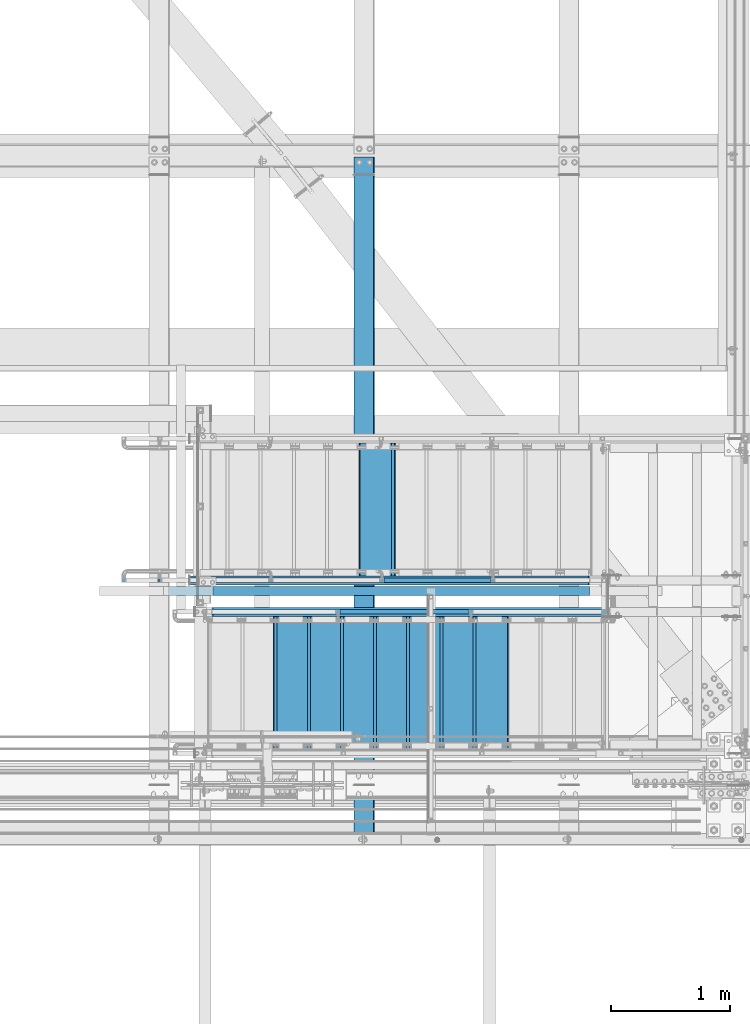
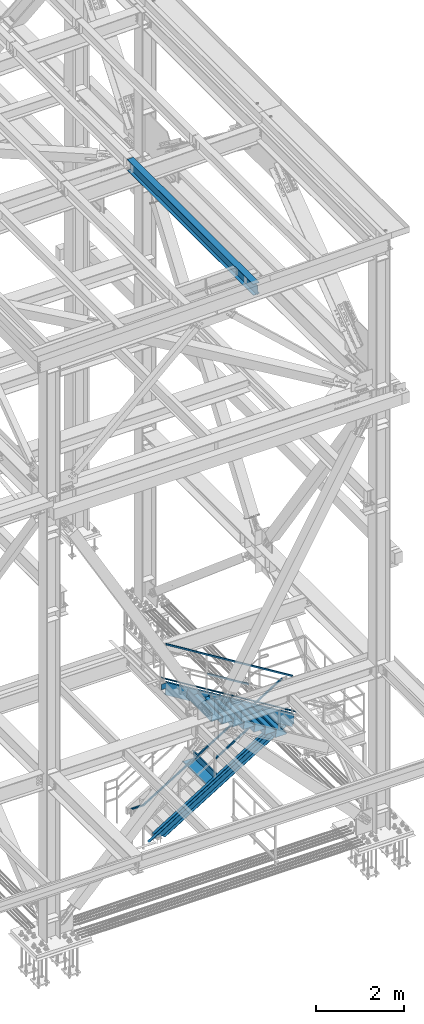
# One storey, part 1947 of 3843: 10 beams, 7 members, 7 elements without a shape of their own.
"""IFC2X3 building model written with IfcOpenShell, lengths in millimetres."""

from ifc_helpers import new_model, si_unit, frame, origin_with_axes, place, context, subcontext, project, spatial, faceted_brep, material, type_object, element, aggregate, save


model = new_model("IFC2X3")

# Units and contexts
model_context = context("Model", 3, precision=1e-05, world=origin_with_axes())
body_context = subcontext(model_context, "Body", "Model", "MODEL_VIEW")
ifc_project = project(units=[si_unit("LENGTHUNIT", "METRE", prefix="MILLI"), si_unit("AREAUNIT", "SQUARE_METRE"), si_unit("VOLUMEUNIT", "CUBIC_METRE"), si_unit("MASSUNIT", "GRAM", prefix="KILO"), si_unit("TIMEUNIT", "SECOND"), si_unit("PLANEANGLEUNIT", "RADIAN"), si_unit("SOLIDANGLEUNIT", "STERADIAN"), si_unit("THERMODYNAMICTEMPERATUREUNIT", "DEGREE_CELSIUS"), si_unit("LUMINOUSINTENSITYUNIT", "LUMEN")], contexts=[model_context])

# Site, building, storey
site_placement = place(None, origin_with_axes())
site = spatial("IfcSite", under=ifc_project, at=site_placement, CompositionType="ELEMENT")
building_placement = place(site_placement, origin_with_axes())
building = spatial("IfcBuilding", under=site, at=building_placement, Name="Undefined", CompositionType="ELEMENT")
storey_placement = place(building_placement, origin_with_axes())
storey = spatial("IfcBuildingStorey", under=building, at=storey_placement, Name="Undefined", CompositionType="ELEMENT", Elevation=0.0)

# Assembly, beam
assembly_1_placement = place(storey_placement, origin_with_axes())
assembly_1 = element("IfcElementAssembly", 1, at=assembly_1_placement, inside=storey, Name="RAIL", AssemblyPlace="NOTDEFINED", PredefinedType="RIGID_FRAME")
ifc_material_1 = material()
beam_type_1 = type_object("IfcBeamType", Name="HSS1-1/2X1-1/2X1/4", PredefinedType="NOTDEFINED")
beam_1_placement = place(assembly_1_placement, frame((84099.3999999465, 16725.9, 33781.9999999847), z_axis=(0.524097425775922, 0.0, -0.851658316635875), x_axis=(-0.851658316635875, 0.0, -0.524097425775922)))
beam_1 = element("IfcBeam", 2, at=beam_1_placement, type_object=beam_type_1, material=ifc_material_1, Name="RAIL", ObjectType="HSS1-1/2X1-1/2X1/4", context=body_context, shape_type="Brep", body=[
    faceted_brep([(-5.39195355401171, -19.0499992350015, -19.0499992349942), (5.39195347770146, -19.0499992350015, 19.0499992349796), (5.39195347770146, 19.0499992350015, 19.0499992349796), (-5.39195355401171, 19.0499992350015, -19.0499992349942), (3.59463559381402, 12.6999993300014, 12.6999993299833), (3.59463559381402, -12.6999993300014, 12.6999993299833), (-3.59463567009516, -12.6999993300014, -12.6999993299978), (-3.59463567009516, 12.6999993300014, -12.6999993299978), (4270.24785764143, -19.0499992349996, 19.0499992372643), (4270.24785764143, 19.0499992349996, 19.0499992372643), (4259.4639506097, 19.0499992349996, -19.049999232695), (4259.4639506097, -19.0499992349996, -19.049999232695), (4261.26126849362, -12.6999993299996, -12.6999993277132), (4261.26126849362, 12.6999993299996, -12.6999993277132), (4268.45053975753, 12.6999993299996, 12.6999993322825), (4268.45053975753, -12.6999993299996, 12.6999993322825), (4530.68139334727, 19.0499992350015, -185.9530417606), (4530.68139334727, -19.0499992350015, -185.9530417606), (4518.20132390667, -19.0499992350015, -133.536750079667), (4518.20132390667, 19.0499992350015, -133.536750079667), (4528.60138172143, -12.6999993300014, -177.216992926999), (4528.60138172143, 12.6999993300014, -177.216992926999), (4520.28133553253, 12.6999993300014, -142.27279891328), (4520.28133553253, -12.6999993300014, -142.27279891328)], [[[0, 1, 2, 3], [4, 5, 6, 7]], [[2, 1, 8, 9]], [[0, 3, 10, 11]], [[7, 6, 12, 13]], [[5, 4, 14, 15]], [[11, 10, 16, 17]], [[8, 1, 0, 11, 17, 18]], [[9, 8, 18, 19]], [[10, 3, 2, 9, 19, 16]], [[13, 12, 20, 21]], [[14, 4, 7, 13, 21, 22]], [[15, 14, 22, 23]], [[12, 6, 5, 15, 23, 20]], [[19, 18, 17, 16], [22, 21, 20, 23]]]),
])

# Assembly, member
assembly_2_placement = place(storey_placement, origin_with_axes())
assembly_2 = element("IfcElementAssembly", 3, at=assembly_2_placement, inside=storey, Name="RAIL", AssemblyPlace="NOTDEFINED", PredefinedType="RIGID_FRAME")
member_type_1 = type_object("IfcMemberType", Name="HSS1-1/2X1-1/2X1/4", PredefinedType="NOTDEFINED")
member_1_placement = place(assembly_2_placement, frame((83091.8666666392, 16459.2, 34134.343589332), z_axis=(0.524097425775922, 0.0, 0.851658316635875), x_axis=(-0.851658316635873, 0.0, 0.524097425775925)))
member_1 = element("IfcMember", 4, at=member_1_placement, type_object=member_type_1, material=ifc_material_1, Name="RAIL", ObjectType="HSS1-1/2X1-1/2X1/4", context=body_context, shape_type="Brep", body=[
    faceted_brep([(10.6450480494532, -19.0499992350015, -19.0499992349796), (34.091200960931, -19.0499992350015, 19.0499992349942), (34.091200960931, 19.0499992350015, 19.0499992349942), (10.6450480494532, 19.0499992350015, -19.0499992349796), (30.1835087105574, 12.6999993300014, 12.6999993299978), (30.1835087105574, -12.6999993300014, 12.6999993299978), (14.5527402998268, -12.6999993300014, -12.6999993299833), (14.5527402998268, 12.6999993300014, -12.6999993299833), (1283.14284868913, 19.0499992350015, -19.0499992342957), (1283.14284868913, -19.0499992350015, -19.0499992342957), (1306.58900160061, -19.0499992350015, 19.0499992356781), (1306.58900160061, 19.0499992350015, 19.0499992356781), (1302.68130935024, -12.6999993300014, 12.6999993306817), (1302.68130935024, 12.6999993300014, 12.6999993306817), (1287.0505409395, 12.6999993300014, -12.6999993292993), (1287.0505409395, -12.6999993300014, -12.6999993292993)], [[[0, 1, 2, 3], [4, 5, 6, 7]], [[8, 9, 0, 3]], [[9, 10, 1, 0]], [[10, 11, 2, 1]], [[11, 8, 3, 2]], [[10, 9, 8, 11], [12, 13, 14, 15]], [[13, 12, 5, 4]], [[14, 13, 4, 7]], [[15, 14, 7, 6]], [[12, 15, 6, 5]]]),
])

# Member
member_2_placement = place(assembly_1_placement, frame((82340.4500000268, 16725.9, 32166.1692304858), z_axis=(-0.524097425775922, 0.0, 0.851658316635875), x_axis=(0.851658316635872, 0.0, 0.524097425775926)))
member_2 = element("IfcMember", 5, at=member_2_placement, type_object=member_type_1, material=ifc_material_1, Name="RAIL", ObjectType="HSS1-1/2X1-1/2X1/4", context=body_context, shape_type="Brep", body=[
    faceted_brep([(1089.12111513855, -19.0499999999993, 19.0499992355581), (1065.67496222707, -19.0499992350015, -19.0499992344157), (1065.67496222707, 19.0499992350015, -19.0499992344157), (1089.12111513855, 19.0499992350015, 19.0499992355581), (1085.21342288818, -12.6999993300014, 12.6999993305617), (1085.21342288818, 12.6999993300014, 12.6999993305617), (1069.58265447745, 12.6999993300014, -12.6999993294194), (1069.58265447745, -12.6999993300014, -12.6999993294194), (10.6450480494532, 19.0499992350015, -19.0499992349796), (34.091200960931, 19.0499992350015, 19.0499992349942), (34.091200960931, -19.0499992350015, 19.0499992349942), (10.6450480494532, -19.0499992350015, -19.0499992349796), (30.1835087105574, 12.6999993300014, 12.6999993299978), (30.1835087105574, -12.6999993300014, 12.6999993299978), (14.5527402998268, -12.6999993300014, -12.6999993299833), (14.5527402998268, 12.6999993300014, -12.6999993299833)], [[[0, 1, 2, 3], [4, 5, 6, 7]], [[8, 9, 3, 2]], [[9, 10, 0, 3]], [[10, 11, 1, 0]], [[11, 8, 2, 1]], [[11, 10, 9, 8], [12, 13, 14, 15]], [[14, 13, 4, 7]], [[15, 14, 7, 6]], [[12, 15, 6, 5]], [[13, 12, 5, 4]]]),
])

aggregate(assembly_1, [member_2, beam_1])

member_3_placement = place(assembly_2_placement, frame((80898.9999999723, 16459.2, 36017.2000000046), z_axis=(-0.524097425775922, 0.0, -0.851658316635875), x_axis=(0.851658316635874, 0.0, -0.524097425775923)))
member_3 = element("IfcMember", 6, at=member_3_placement, type_object=member_type_1, material=ifc_material_1, Name="RAIL", ObjectType="HSS1-1/2X1-1/2X1/4", context=body_context, shape_type="Brep", body=[
    faceted_brep([(-3.59463567009516, 12.6999993300014, -12.6999993299978), (-3.59463567009516, -12.6999993300014, -12.6999993299978), (3899.15051320208, -12.6999993300014, -12.6999993279023), (3899.15051320208, 12.6999993300014, -12.6999993279023), (3.59463559381402, -12.6999993300014, 12.6999993299833), (3884.957116021, -12.6999993300014, 12.6999993320496), (3.59463559381402, 12.6999993300014, 12.6999993299833), (3884.957116021, 12.6999993300014, 12.6999993320496), (-5.39195355401171, 19.0499992350015, -19.0499992349942), (5.39195347770146, 19.0499992350015, 19.0499992349796), (3881.40876659161, 19.0499992350015, 19.0499992370605), (3902.69886263146, 19.0499992350015, -19.0499992328987), (5.39195347770146, -19.0499992350015, 19.0499992349796), (3881.40876659161, -19.0499992350015, 19.0499992370605), (-5.39195355401171, -19.0499992350015, -19.0499992349942), (3902.69886263146, -19.0499992350015, -19.0499992328987)], [[[0, 1, 2, 3]], [[1, 4, 5, 2]], [[4, 6, 7, 5]], [[6, 0, 3, 7]], [[8, 9, 10, 11]], [[9, 12, 13, 10]], [[12, 14, 15, 13]], [[14, 8, 11, 15]], [[13, 15, 11, 10], [5, 7, 3, 2]], [[14, 12, 9, 8], [6, 4, 1, 0]]]),
])

aggregate(assembly_2, [member_1, member_3])

# Assembly, beams
assembly_3_placement = place(storey_placement, origin_with_axes())
assembly_3 = element("IfcElementAssembly", 7, at=assembly_3_placement, inside=storey, Name="STAIR", AssemblyPlace="NOTDEFINED", PredefinedType="RIGID_FRAME")
ifc_material_2 = material(Name="STEEL/ASTM A1011")
beam_type_2 = type_object("IfcBeamType", PredefinedType="NOTDEFINED")
beam_2_placement = place(assembly_3_placement, frame((81432.3999999869, 15862.300000067, 34604.9355769223), z_axis=(0.0, 1.0, 0.0), x_axis=(1.0, 0.0, 0.0)))
beam_2 = element("IfcBeam", 8, at=beam_2_placement, type_object=beam_type_2, material=ifc_material_2, Name="TREAD", context=body_context, shape_type="Brep", body=[
    faceted_brep([(0.0, -1.58750000000146, -558.799999999999), (0.0, -1.58750000000146, 558.799999999999), (0.0, 1.58750000000146, 558.799999999999), (0.0, 1.58750000000146, -558.799999999999), (21.7215083258779, 1.58750000000146, 558.799999999999), (21.7215083258779, 1.58750000000146, -558.799999999999), (25.3999999999942, -1.58750000000146, -558.799999999999), (25.3999999999942, -1.58750000000146, 558.799999999999), (-11.1830371286633, 224.325961538467, 558.799999999999), (-11.1830371286633, 224.325961538467, -558.799999999999), (-7.50454545454704, 221.150961538464, -558.799999999999), (-7.50454545454704, 221.150961538464, 558.799999999999), (293.616962871325, 224.325961538467, 558.799999999999), (293.616962871325, 224.325961538467, -558.799999999999), (290.876539379024, 221.150961538464, -558.799999999999), (290.876539379024, 221.150961538464, 558.799999999999), (299.585432747743, 183.924011605752, 558.799999999999), (299.585432747743, 183.924011605752, -558.799999999999), (296.444520385252, 183.460013188564, 558.799999999999), (296.444520385252, 183.460013188564, -558.799999999999)], [[[0, 1, 2, 3]], [[3, 2, 4, 5]], [[1, 0, 6, 7]], [[5, 4, 8, 9]], [[7, 6, 10, 11]], [[9, 8, 12, 13]], [[11, 10, 14, 15]], [[13, 12, 16, 17]], [[12, 8, 4, 2, 1, 7, 11, 15, 18, 16]], [[15, 14, 19, 18]], [[14, 10, 6, 0, 3, 5, 9, 13, 17, 19]], [[18, 19, 17, 16]]]),
])
beam_3_placement = place(assembly_3_placement, frame((81711.7999999869, 15862.300000067, 34432.9971153838), z_axis=(0.0, 1.0, 0.0), x_axis=(1.0, 0.0, 0.0)))
beam_3 = element("IfcBeam", 9, at=beam_3_placement, type_object=beam_type_2, material=ifc_material_2, Name="TREAD", context=body_context, shape_type="Brep", body=[
    faceted_brep([(0.0, -1.58750000000146, -558.799999999999), (0.0, -1.58750000000146, 558.799999999999), (0.0, 1.58750000000146, 558.799999999999), (0.0, 1.58750000000146, -558.799999999999), (21.7215083258779, 1.58750000000146, 558.799999999999), (21.7215083258779, 1.58750000000146, -558.799999999999), (25.3999999999942, -1.58750000000146, -558.799999999999), (25.3999999999942, -1.58750000000146, 558.799999999999), (-11.1830371286633, 224.325961538467, 558.799999999999), (-11.1830371286633, 224.325961538467, -558.799999999999), (-7.50454545454704, 221.150961538464, -558.799999999999), (-7.50454545454704, 221.150961538464, 558.799999999999), (293.616962871325, 224.325961538467, 558.799999999999), (293.616962871325, 224.325961538467, -558.799999999999), (290.876539379024, 221.150961538464, -558.799999999999), (290.876539379024, 221.150961538464, 558.799999999999), (299.585432747743, 183.924011605752, 558.799999999999), (299.585432747743, 183.924011605752, -558.799999999999), (296.444520385252, 183.460013188564, 558.799999999999), (296.444520385252, 183.460013188564, -558.799999999999)], [[[0, 1, 2, 3]], [[3, 2, 4, 5]], [[1, 0, 6, 7]], [[5, 4, 8, 9]], [[7, 6, 10, 11]], [[9, 8, 12, 13]], [[11, 10, 14, 15]], [[13, 12, 16, 17]], [[12, 8, 4, 2, 1, 7, 11, 15, 18, 16]], [[15, 14, 19, 18]], [[14, 10, 6, 0, 3, 5, 9, 13, 17, 19]], [[18, 19, 17, 16]]]),
])
beam_4_placement = place(assembly_3_placement, frame((81991.1999999869, 15862.300000067, 34261.0586538454), z_axis=(0.0, 1.0, 0.0), x_axis=(1.0, 0.0, 0.0)))
beam_4 = element("IfcBeam", 10, at=beam_4_placement, type_object=beam_type_2, material=ifc_material_2, Name="TREAD", context=body_context, shape_type="Brep", body=[
    faceted_brep([(0.0, -1.58750000000146, -558.799999999999), (0.0, -1.58750000000146, 558.799999999999), (0.0, 1.58750000000146, 558.799999999999), (0.0, 1.58750000000146, -558.799999999999), (21.7215083258779, 1.58750000000146, 558.799999999999), (21.7215083258779, 1.58750000000146, -558.799999999999), (25.3999999999942, -1.58750000000146, -558.799999999999), (25.3999999999942, -1.58750000000146, 558.799999999999), (-11.1830371286633, 224.325961538467, 558.799999999999), (-11.1830371286633, 224.325961538467, -558.799999999999), (-7.50454545454704, 221.150961538464, -558.799999999999), (-7.50454545454704, 221.150961538464, 558.799999999999), (293.616962871325, 224.325961538467, 558.799999999999), (293.616962871325, 224.325961538467, -558.799999999999), (290.876539379024, 221.150961538464, -558.799999999999), (290.876539379024, 221.150961538464, 558.799999999999), (299.585432747743, 183.924011605752, 558.799999999999), (299.585432747743, 183.924011605752, -558.799999999999), (296.444520385252, 183.460013188564, 558.799999999999), (296.444520385252, 183.460013188564, -558.799999999999)], [[[0, 1, 2, 3]], [[3, 2, 4, 5]], [[1, 0, 6, 7]], [[5, 4, 8, 9]], [[7, 6, 10, 11]], [[9, 8, 12, 13]], [[11, 10, 14, 15]], [[13, 12, 16, 17]], [[12, 8, 4, 2, 1, 7, 11, 15, 18, 16]], [[15, 14, 19, 18]], [[14, 10, 6, 0, 3, 5, 9, 13, 17, 19]], [[18, 19, 17, 16]]]),
])
beam_5_placement = place(assembly_3_placement, frame((82270.5999999869, 15862.300000067, 34089.1201923069), z_axis=(0.0, 1.0, 0.0), x_axis=(1.0, 0.0, 0.0)))
beam_5 = element("IfcBeam", 11, at=beam_5_placement, type_object=beam_type_2, material=ifc_material_2, Name="TREAD", context=body_context, shape_type="Brep", body=[
    faceted_brep([(0.0, -1.58750000000146, -558.799999999999), (0.0, -1.58750000000146, 558.799999999999), (0.0, 1.58750000000146, 558.799999999999), (0.0, 1.58750000000146, -558.799999999999), (21.7215083258779, 1.58750000000146, 558.799999999999), (21.7215083258779, 1.58750000000146, -558.799999999999), (25.3999999999942, -1.58750000000146, -558.799999999999), (25.3999999999942, -1.58750000000146, 558.799999999999), (-11.1830371286633, 224.325961538467, 558.799999999999), (-11.1830371286633, 224.325961538467, -558.799999999999), (-7.50454545454704, 221.150961538464, -558.799999999999), (-7.50454545454704, 221.150961538464, 558.799999999999), (293.616962871325, 224.325961538467, 558.799999999999), (293.616962871325, 224.325961538467, -558.799999999999), (290.876539379024, 221.150961538464, -558.799999999999), (290.876539379024, 221.150961538464, 558.799999999999), (299.585432747743, 183.924011605752, 558.799999999999), (299.585432747743, 183.924011605752, -558.799999999999), (296.444520385252, 183.460013188564, 558.799999999999), (296.444520385252, 183.460013188564, -558.799999999999)], [[[0, 1, 2, 3]], [[3, 2, 4, 5]], [[1, 0, 6, 7]], [[5, 4, 8, 9]], [[7, 6, 10, 11]], [[9, 8, 12, 13]], [[11, 10, 14, 15]], [[13, 12, 16, 17]], [[12, 8, 4, 2, 1, 7, 11, 15, 18, 16]], [[15, 14, 19, 18]], [[14, 10, 6, 0, 3, 5, 9, 13, 17, 19]], [[18, 19, 17, 16]]]),
])
beam_6_placement = place(assembly_3_placement, frame((82549.9999999869, 15862.300000067, 33917.1817307685), z_axis=(0.0, 1.0, 0.0), x_axis=(1.0, 0.0, 0.0)))
beam_6 = element("IfcBeam", 12, at=beam_6_placement, type_object=beam_type_2, material=ifc_material_2, Name="TREAD", context=body_context, shape_type="Brep", body=[
    faceted_brep([(0.0, -1.58750000000146, -558.799999999999), (0.0, -1.58750000000146, 558.799999999999), (0.0, 1.58750000000146, 558.799999999999), (0.0, 1.58750000000146, -558.799999999999), (21.7215083258779, 1.58750000000146, 558.799999999999), (21.7215083258779, 1.58750000000146, -558.799999999999), (25.3999999999942, -1.58750000000146, -558.799999999999), (25.3999999999942, -1.58750000000146, 558.799999999999), (-11.1830371286633, 224.325961538467, 558.799999999999), (-11.1830371286633, 224.325961538467, -558.799999999999), (-7.50454545454704, 221.150961538464, -558.799999999999), (-7.50454545454704, 221.150961538464, 558.799999999999), (293.616962871325, 224.325961538467, 558.799999999999), (293.616962871325, 224.325961538467, -558.799999999999), (290.876539379024, 221.150961538464, -558.799999999999), (290.876539379024, 221.150961538464, 558.799999999999), (299.585432747743, 183.924011605752, 558.799999999999), (299.585432747743, 183.924011605752, -558.799999999999), (296.444520385252, 183.460013188564, 558.799999999999), (296.444520385252, 183.460013188564, -558.799999999999)], [[[0, 1, 2, 3]], [[3, 2, 4, 5]], [[1, 0, 6, 7]], [[5, 4, 8, 9]], [[7, 6, 10, 11]], [[9, 8, 12, 13]], [[11, 10, 14, 15]], [[13, 12, 16, 17]], [[12, 8, 4, 2, 1, 7, 11, 15, 18, 16]], [[15, 14, 19, 18]], [[14, 10, 6, 0, 3, 5, 9, 13, 17, 19]], [[18, 19, 17, 16]]]),
])
beam_7_placement = place(assembly_3_placement, frame((82829.3999999869, 15862.300000067, 33745.24326923), z_axis=(0.0, 1.0, 0.0), x_axis=(1.0, 0.0, 0.0)))
beam_7 = element("IfcBeam", 13, at=beam_7_placement, type_object=beam_type_2, material=ifc_material_2, Name="TREAD", context=body_context, shape_type="Brep", body=[
    faceted_brep([(0.0, -1.58750000000146, -558.799999999999), (0.0, -1.58750000000146, 558.799999999999), (0.0, 1.58750000000146, 558.799999999999), (0.0, 1.58750000000146, -558.799999999999), (21.7215083258779, 1.58750000000146, 558.799999999999), (21.7215083258779, 1.58750000000146, -558.799999999999), (25.3999999999942, -1.58750000000146, -558.799999999999), (25.3999999999942, -1.58750000000146, 558.799999999999), (-11.1830371286633, 224.325961538467, 558.799999999999), (-11.1830371286633, 224.325961538467, -558.799999999999), (-7.50454545454704, 221.150961538464, -558.799999999999), (-7.50454545454704, 221.150961538464, 558.799999999999), (293.616962871325, 224.325961538467, 558.799999999999), (293.616962871325, 224.325961538467, -558.799999999999), (290.876539379024, 221.150961538464, -558.799999999999), (290.876539379024, 221.150961538464, 558.799999999999), (299.585432747743, 183.924011605752, 558.799999999999), (299.585432747743, 183.924011605752, -558.799999999999), (296.444520385252, 183.460013188564, 558.799999999999), (296.444520385252, 183.460013188564, -558.799999999999)], [[[0, 1, 2, 3]], [[3, 2, 4, 5]], [[1, 0, 6, 7]], [[5, 4, 8, 9]], [[7, 6, 10, 11]], [[9, 8, 12, 13]], [[11, 10, 14, 15]], [[13, 12, 16, 17]], [[12, 8, 4, 2, 1, 7, 11, 15, 18, 16]], [[15, 14, 19, 18]], [[14, 10, 6, 0, 3, 5, 9, 13, 17, 19]], [[18, 19, 17, 16]]]),
])
beam_8_placement = place(assembly_3_placement, frame((83108.7999999869, 15862.300000067, 33573.3048076915), z_axis=(0.0, 1.0, 0.0), x_axis=(1.0, 0.0, 0.0)))
beam_8 = element("IfcBeam", 14, at=beam_8_placement, type_object=beam_type_2, material=ifc_material_2, Name="TREAD", context=body_context, shape_type="Brep", body=[
    faceted_brep([(0.0, -1.58750000000146, -558.799999999999), (0.0, -1.58750000000146, 558.799999999999), (0.0, 1.58750000000146, 558.799999999999), (0.0, 1.58750000000146, -558.799999999999), (21.7215083258779, 1.58750000000146, 558.799999999999), (21.7215083258779, 1.58750000000146, -558.799999999999), (25.3999999999942, -1.58750000000146, -558.799999999999), (25.3999999999942, -1.58750000000146, 558.799999999999), (-11.1830371286633, 224.325961538467, 558.799999999999), (-11.1830371286633, 224.325961538467, -558.799999999999), (-7.50454545454704, 221.150961538464, -558.799999999999), (-7.50454545454704, 221.150961538464, 558.799999999999), (293.616962871325, 224.325961538467, 558.799999999999), (293.616962871325, 224.325961538467, -558.799999999999), (290.876539379024, 221.150961538464, -558.799999999999), (290.876539379024, 221.150961538464, 558.799999999999), (299.585432747743, 183.924011605752, 558.799999999999), (299.585432747743, 183.924011605752, -558.799999999999), (296.444520385252, 183.460013188564, 558.799999999999), (296.444520385252, 183.460013188564, -558.799999999999)], [[[0, 1, 2, 3]], [[3, 2, 4, 5]], [[1, 0, 6, 7]], [[5, 4, 8, 9]], [[7, 6, 10, 11]], [[9, 8, 12, 13]], [[11, 10, 14, 15]], [[13, 12, 16, 17]], [[12, 8, 4, 2, 1, 7, 11, 15, 18, 16]], [[15, 14, 19, 18]], [[14, 10, 6, 0, 3, 5, 9, 13, 17, 19]], [[18, 19, 17, 16]]]),
])

# Assembly, beam, member
assembly_4_placement = place(storey_placement, origin_with_axes())
assembly_4 = element("IfcElementAssembly", 15, at=assembly_4_placement, inside=storey, Name="STAIR", AssemblyPlace="NOTDEFINED", PredefinedType="RIGID_FRAME")
beam_9_placement = place(assembly_4_placement, frame((82448.4000000127, 17322.7999999318, 31681.9817307684), z_axis=(0.0, -1.0, 0.0), x_axis=(-1.0, 0.0, 0.0)))
beam_9 = element("IfcBeam", 16, at=beam_9_placement, type_object=beam_type_2, material=ifc_material_2, Name="TREAD", context=body_context, shape_type="Brep", body=[
    faceted_brep([(0.0, -1.58750000000146, -558.799999999999), (0.0, -1.58750000000146, 558.799999999999), (0.0, 1.58750000000146, 558.799999999999), (0.0, 1.58750000000146, -558.799999999999), (21.7215083258779, 1.58750000000146, 558.799999999999), (21.7215083258779, 1.58750000000146, -558.799999999999), (25.3999999999942, -1.58750000000146, -558.799999999999), (25.3999999999942, -1.58750000000146, 558.799999999999), (-11.1830371286633, 224.325961538467, 558.799999999999), (-11.1830371286633, 224.325961538467, -558.799999999999), (-7.50454545454704, 221.150961538464, -558.799999999999), (-7.50454545454704, 221.150961538464, 558.799999999999), (293.616962871325, 224.325961538467, 558.799999999999), (293.616962871325, 224.325961538467, -558.799999999999), (290.876539379024, 221.150961538464, -558.799999999999), (290.876539379024, 221.150961538464, 558.799999999999), (299.585432747743, 183.924011605752, 558.799999999999), (299.585432747743, 183.924011605752, -558.799999999999), (296.444520385252, 183.460013188564, 558.799999999999), (296.444520385252, 183.460013188564, -558.799999999999)], [[[0, 1, 2, 3]], [[3, 2, 4, 5]], [[1, 0, 6, 7]], [[5, 4, 8, 9]], [[7, 6, 10, 11]], [[9, 8, 12, 13]], [[11, 10, 14, 15]], [[13, 12, 16, 17]], [[12, 8, 4, 2, 1, 7, 11, 15, 18, 16]], [[15, 14, 19, 18]], [[14, 10, 6, 0, 3, 5, 9, 13, 17, 19]], [[18, 19, 17, 16]]]),
])
ifc_material_3 = material(Name="STEEL/A36")
member_type_2 = type_object("IfcMemberType", Name="C12X20.7", PredefinedType="NOTDEFINED")
member_4_placement = place(assembly_4_placement, frame((80622.4331760373, 16725.9000000001, 30426.4072725339), z_axis=(-0.524097425775922, 0.0, 0.851658316635875), x_axis=(0.851658316635872, 0.0, 0.524097425775926)))
member_4 = element("IfcMember", 17, at=member_4_placement, type_object=member_type_2, material=ifc_material_3, Name="STAIR", ObjectType="C12X20.7", context=body_context, shape_type="Brep", body=[
    faceted_brep([(345.336078011489, 30.1624999999985, -134.67492749968), (363.81644331853, -38.0999999999985, -146.047459999656), (4104.54950987584, -38.0999999999985, -146.047459997651), (4111.54799141634, 30.1624999999985, -134.674927497657), (374.139320815477, -38.0999999999985, -152.399999999641), (4100.64025449008, -38.0999999999985, -152.399999997648), (374.139320815477, 38.0999999999985, -152.399999999641), (4100.64025449008, 38.0999999999985, -152.399999997648), (4215.234394315, 38.0999999999985, 33.8154771632035), (4215.234394315, 30.1624999999985, 33.8154771632035), (4258.49863680001, 30.1624999999985, 7.19132793384051), (4258.49863680001, 38.0999999999985, 7.19132793384051), (4295.10684199037, 38.0999999999985, 66.679661350754), (4295.10684199037, 30.1624999999985, 66.679661350754), (4155.81129172289, 38.0999999999985, 152.400000002061), (4155.81129172289, -38.0999999999985, 152.400000002061), (4166.13416921983, -38.0999999999985, 146.047460002072), (4184.61453452687, 30.1624999999985, 134.674927502092), (209.754625973874, -38.0999999999985, 152.399999999951), (205.845370588111, -38.0999999999985, 146.047459999954), (198.846889047592, 30.1624999999985, 134.674927499964), (118.859434858809, 30.1624999999985, 4.69531448134148), (118.859434858809, 38.0999999999985, 4.69531448134148), (209.754625973874, 38.0999999999985, 152.399999999951)], [[[0, 1, 2, 3]], [[1, 4, 5, 2]], [[4, 6, 7, 5]], [[3, 2, 5, 7, 8, 9]], [[10, 9, 8, 11]], [[12, 13, 10, 11]], [[14, 15, 16, 17, 13, 12]], [[16, 15, 18, 19]], [[17, 16, 19, 20]], [[0, 3, 9, 10, 13, 17, 20, 21]], [[6, 4, 1, 0, 21, 22]], [[14, 12, 11, 8, 7, 6, 22, 23]], [[15, 14, 23, 18]], [[22, 21, 20, 19, 18, 23]]]),
])
aggregate(assembly_4, [member_4, beam_9])

# Member
member_5_placement = place(assembly_3_placement, frame((84458.5168239583, 16459.1999999992, 32610.8072725339), z_axis=(0.524097425775922, 0.0, 0.851658316635875), x_axis=(-0.851658316635873, 0.0, 0.524097425775925)))
member_5 = element("IfcMember", 18, at=member_5_placement, type_object=member_type_2, material=ifc_material_3, Name="STAIR", ObjectType="C12X20.7", context=body_context, shape_type="Brep", body=[
    faceted_brep([(252.812185612245, 30.1624999999985, -92.6492311278125), (252.812185612245, 38.0999999999985, -92.6492311278125), (216.04248168027, 38.0999999999985, -152.399999999732), (216.04248168027, -38.0999999999985, -152.399999999732), (219.951737066032, -38.0999999999985, -146.04745999974), (226.950218606544, 30.1624999999985, -134.674927499742), (209.547943127269, 30.1624999999985, -66.0250818984641), (209.547943127269, 38.0999999999985, -66.0250818984641), (343.963378181186, 38.0999999999985, 152.400000000023), (343.963378181186, -38.0999999999985, 152.400000000023), (4252.73983497309, -38.0999999999985, 152.400000002119), (4252.73983497309, 38.0999999999985, 152.400000002119), (340.054122795424, -38.0999999999985, 146.047460000031), (4263.06271247005, -38.0999999999985, 146.047460002126), (333.055641254912, 30.1624999999985, 134.674927500033), (4281.5430777771, 30.1624999999985, 134.674927502143), (4381.21932463384, 30.1624999999985, 73.335698649229), (4381.21932463384, 38.0999999999985, 73.335698649229), (4301.34687694577, 30.1624999999985, -56.4570288058021), (4301.34687694577, 38.0999999999985, -56.4570288058021), (4214.81839197576, 30.1624999999985, -3.2087303471053), (4214.81839197576, 38.0999999999985, -3.2087303471053), (4133.91611678243, 30.1624999999985, -134.674927497661), (4126.91763524192, -38.0999999999985, -146.047459997644), (4123.00837985616, -38.0999999999985, -152.399999997637), (4123.00837985616, 38.0999999999985, -152.399999997637)], [[[0, 1, 2, 3, 4, 5]], [[6, 7, 1, 0]], [[8, 9, 10, 11]], [[9, 12, 13, 10]], [[12, 14, 15, 13]], [[11, 10, 13, 15, 16, 17]], [[17, 16, 18, 19]], [[18, 20, 21, 19]], [[22, 23, 24, 25, 21, 20]], [[23, 22, 5, 4]], [[24, 23, 4, 3]], [[25, 24, 3, 2]], [[8, 11, 17, 19, 21, 25, 2, 1, 7]], [[14, 12, 9, 8, 7, 6]], [[22, 20, 18, 16, 15, 14, 6, 0, 5]]]),
])

aggregate(assembly_3, [member_5, beam_2, beam_3, beam_4, beam_5, beam_6, beam_7, beam_8])

# Assembly, beam
assembly_5_placement = place(storey_placement, origin_with_axes())
assembly_5 = element("IfcElementAssembly", 19, at=assembly_5_placement, inside=storey, Name="BEAM", AssemblyPlace="NOTDEFINED", PredefinedType="RIGID_FRAME")
ifc_material_4 = material(Name="STEEL/A992")
beam_type_3 = type_object("IfcBeamType", Name="W12X26", PredefinedType="NOTDEFINED")
beam_10_placement = place(assembly_5_placement, frame((82191.1092623524, 14490.7000000001, 46539.0560104389), z_axis=(-0.0211520980073474, 0.0, 0.999776269347241), x_axis=(0.0, 1.0, 0.0)))
beam_10 = element("IfcBeam", 20, at=beam_10_placement, type_object=beam_type_3, material=ifc_material_4, Name="BEAM", ObjectType="W12X26", context=body_context, shape_type="Brep", body=[
    faceted_brep([(20.6374999998825, -3.17500000016298, -130.175000008305), (20.6374999998825, 3.1749999998865, -130.175000008305), (77.7875001906159, 3.1749999998865, -130.175000008334), (77.7875001906159, -3.17500000016298, -130.175000008334), (82.6475797086623, 3.1749999998865, -131.141729930918), (82.6475797086623, -3.17500000014843, -131.141729930918), (86.767756176816, 3.17499999987194, -133.894743831384), (86.767756176816, -3.17500000014843, -133.894743831377), (89.5207700772935, 3.17499999987194, -138.014920299524), (89.5207700772935, -3.17500000014843, -138.014920299516), (90.487499999881, -3.17500000014843, -142.874999817534), (90.487499999881, 3.17499999987194, -142.874999817541), (90.487499999881, 3.17499999987194, -146.049999999763), (90.487499999881, 82.5500000003231, -146.049999999828), (90.487499999881, 82.5500000003085, -155.574999999815), (90.487499999881, -82.5500000006286, -155.57499999967), (90.487499999881, -82.5500000006141, -146.04999999969), (90.487499999881, -3.17500000017753, -146.049999999756), (5803.89999999989, -82.5500000003231, 146.049999999843), (5803.89999999989, -82.5500000003085, 155.57499999983), (90.487499999881, -82.5500000003085, 155.574980215941), (90.487499999881, -82.5500000003231, 146.049999999843), (5803.89999999989, 82.5500000006141, 155.574999999684), (90.487499999881, 82.5500000006141, 155.574999999684), (5803.89999999989, 82.5500000006141, 146.049999999705), (90.487499999881, 82.5500000006141, 146.049999999705), (5803.89999999989, 3.17500000016298, 146.04999999977), (90.487499999881, 3.17500000016298, 146.04999999977), (77.7875001906159, -3.1749999998865, 130.174999990406), (77.7875001906159, 3.17500000014843, 130.174999990399), (20.6374999998825, 3.17500000014843, 130.174999990428), (20.6374999998825, -3.1749999998865, 130.174999990435), (82.6475797086623, -3.1749999998865, 131.14172991299), (82.6475797086623, 3.17500000013388, 131.14172991299), (86.767756176816, -3.1749999998865, 133.894743813456), (86.767756176816, 3.17500000014843, 133.894743813449), (89.5207700772935, -3.1749999998865, 138.014920281596), (89.5207700772935, 3.17500000016298, 138.014920281588), (90.487499999881, -3.1749999998865, 142.874999799613), (90.487499999881, 3.17500000016298, 142.874999799598), (90.487499999881, -3.1749999998865, 146.04999999977), (5803.89999999989, -3.1749999998865, 146.04999999977), (5803.89999999989, 3.17499999987194, -146.049999999763), (5803.89999999989, -3.17500000017753, -146.049999999756), (5803.89999999989, -82.5500000006141, -146.04999999969), (5803.89999999989, -82.5500000006286, -155.57499999967), (5803.89999999989, 82.5500000003085, -155.574999999815), (5803.89999999989, 82.5500000003231, -146.049999999828), (20.6374999998825, 3.1749999998865, -113.125000025924), (20.6374999998825, 3.17500000013388, 117.474999970342)], [[[0, 1, 2, 3]], [[3, 2, 4, 5]], [[5, 4, 6, 7]], [[7, 6, 8, 9]], [[10, 11, 12, 13, 14, 15, 16, 17]], [[9, 8, 11, 10]], [[18, 19, 20, 21]], [[19, 22, 23, 20]], [[22, 24, 25, 23]], [[24, 26, 27, 25]], [[28, 29, 30, 31]], [[32, 33, 29, 28]], [[34, 35, 33, 32]], [[36, 37, 35, 34]], [[38, 39, 37, 36]], [[20, 23, 25, 27, 39, 38, 40, 21]], [[41, 18, 21, 40]], [[42, 26, 24, 22, 19, 18, 41, 43, 44, 45, 46, 47]], [[44, 43, 17, 16]], [[45, 44, 16, 15]], [[46, 45, 15, 14]], [[47, 46, 14, 13]], [[42, 47, 13, 12]], [[6, 4, 2, 1, 48, 49, 30, 29, 33, 35, 37, 39, 27, 26, 42, 12, 11, 8]], [[31, 30, 49, 48, 1, 0]], [[43, 41, 40, 38, 36, 34, 32, 28, 31, 0, 3, 5, 7, 9, 10, 17]]]),
])
aggregate(assembly_5, [beam_10])

# Assembly, member
assembly_6_placement = place(storey_placement, origin_with_axes())
assembly_6 = element("IfcElementAssembly", 21, at=assembly_6_placement, inside=storey, Name="ref.", AssemblyPlace="NOTDEFINED", PredefinedType="RIGID_FRAME")
ifc_material_5 = material(Name="STEEL/Steel_Undefined")
member_type_3 = type_object("IfcMemberType", PredefinedType="NOTDEFINED")
member_6_placement = place(assembly_6_placement, frame((84415.2359906813, 16637.0, 32812.6586128727), z_axis=(0.0, -1.0, 0.0), x_axis=(-0.851658316635873, 0.0, 0.524097425775925)))
member_6 = element("IfcMember", 22, at=member_6_placement, type_object=member_type_3, material=ifc_material_5, Name="ref.", context=body_context, shape_type="Brep", body=[
    faceted_brep([(0.0, 3.17500000000291, -38.0999999999985), (0.0, 3.17500000000291, 38.0999999999985), (4110.08958552884, 3.17499999779102, 38.0999999999985), (4110.08958552884, 3.17499999779102, -38.0999999999985), (0.0, -3.17500000000291, 38.0999999999985), (4110.08958552883, -3.17500000220025, 38.0999999999985), (0.0, -3.17500000000291, -38.0999999999985), (4110.08958552883, -3.17500000220025, -38.0999999999985)], [[[0, 1, 2, 3]], [[1, 4, 5, 2]], [[4, 6, 7, 5]], [[6, 0, 3, 7]], [[5, 7, 3, 2]], [[6, 4, 1, 0]]]),
])
aggregate(assembly_6, [member_6])

assembly_7_placement = place(storey_placement, origin_with_axes())
assembly_7 = element("IfcElementAssembly", 23, at=assembly_7_placement, inside=storey, Name="ref.", AssemblyPlace="NOTDEFINED", PredefinedType="RIGID_FRAME")
member_7_placement = place(assembly_7_placement, frame((80544.2247379629, 16637.0, 30553.4959843881), z_axis=(0.0, 1.0, 0.0), x_axis=(0.851658316635872, 0.0, 0.524097425775926)))
member_7 = element("IfcMember", 24, at=member_7_placement, type_object=member_type_3, material=ifc_material_5, Name="ref.", context=body_context, shape_type="Brep", body=[
    faceted_brep([(0.0, 3.17500000000291, -38.0999999999985), (0.0, 3.17500000000291, 38.0999999999985), (4167.92736051904, 3.17499999776555, 38.0999999999985), (4167.92736051904, 3.17499999776555, -38.0999999999985), (0.0, -3.17500000000291, 38.0999999999985), (4167.92736051904, -3.17500000222572, 38.0999999999985), (0.0, -3.17500000000291, -38.0999999999985), (4167.92736051904, -3.17500000222572, -38.0999999999985)], [[[0, 1, 2, 3]], [[1, 4, 5, 2]], [[4, 6, 7, 5]], [[6, 0, 3, 7]], [[5, 7, 3, 2]], [[6, 4, 1, 0]]]),
])
aggregate(assembly_7, [member_7])

save(model, "model.ifc")
